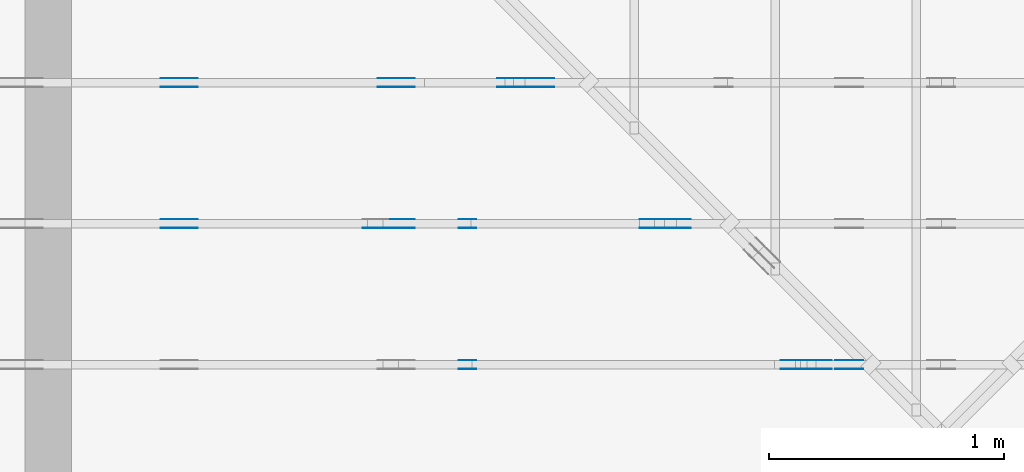
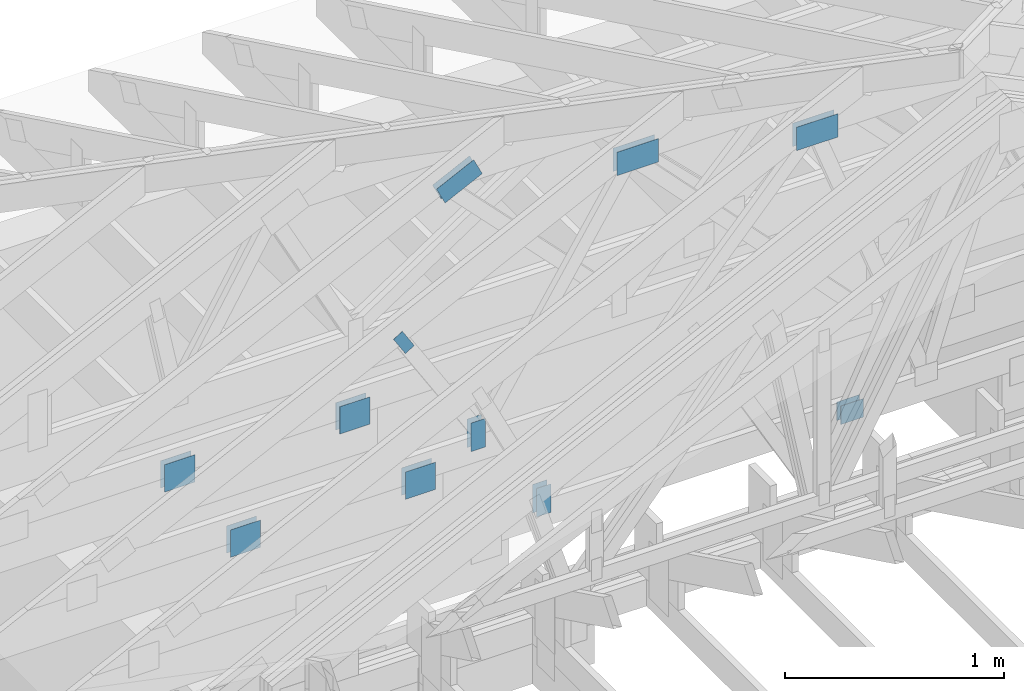
# One storey, part 105 of 159: 21 plates, 3 elements without a shape of their own.
"""IFC2X3 building model written with IfcOpenShell, lengths in millimetres."""

from ifc_helpers import new_model, si_unit, frame, origin, origin_with_axes, origin_2d, place, context, project, spatial, faceted_brep, element, aggregate, save


model = new_model("IFC2X3")

# Units and contexts
model_context = context("Model", 3, precision=1e-05, world=origin())
plan_context = context("Plan", 2, precision=1e-05, world=origin_2d())
ifc_project = project(units=[si_unit("LENGTHUNIT", "METRE", prefix="MILLI"), si_unit("AREAUNIT", "SQUARE_METRE"), si_unit("VOLUMEUNIT", "CUBIC_METRE"), si_unit("SOLIDANGLEUNIT", "STERADIAN"), si_unit("PLANEANGLEUNIT", "RADIAN"), si_unit("MASSUNIT", "GRAM"), si_unit("TIMEUNIT", "SECOND"), si_unit("THERMODYNAMICTEMPERATUREUNIT", "DEGREE_CELSIUS"), si_unit("LUMINOUSINTENSITYUNIT", "LUMEN")], contexts=[model_context, plan_context])

# Site, building, storey
site_placement = place(None, origin_with_axes())
site = spatial("IfcSite", under=ifc_project, at=site_placement, CompositionType="ELEMENT")
building_placement = place(site_placement, origin_with_axes())
building = spatial("IfcBuilding", under=site, at=building_placement, Name="Plan 1", CompositionType="ELEMENT")
storey_placement = place(building_placement, origin_with_axes())
storey = spatial("IfcBuildingStorey", under=building, at=storey_placement, Name="Etasje 1", CompositionType="ELEMENT", Elevation=0.0)

# Assembly, plates
assembly_1_placement = place(storey_placement, frame((19200.01266310149, 9617.999978540158, 1.1021457184401395e-15), z_axis=(1.2246063538223773e-16, 1.0, 6.123031769111886e-17), x_axis=(-1.0, 1.2246063538223773e-16, 0.0)))
assembly_1 = element("IfcElementAssembly", 1, at=assembly_1_placement, inside=storey, Name="V12 (104)", AssemblyPlace="FACTORY", PredefinedType="TRUSS")
plate_1_placement = place(assembly_1_placement, frame((5283.707678150258, 1983.6011962890625, 0.0), z_axis=(0.0, 0.0, 1.0), x_axis=(-1.0, 1.2246063538223773e-16, 0.0)))
plate_1 = element("IfcPlate", 2, at=plate_1_placement, Name="GNT100S 130x218", context=model_context, shape_type="Brep", body=[
    faceted_brep([(218.0001586190083, 130.0, 1.0), (0.0001586190082889516, 130.0, 1.0), (0.0001586190082889516, 0.0, 1.0), (218.0001586190083, 0.0, 1.0), (0.0001586190082889516, 130.0, 1.9424584538765444e-20), (218.0001586190083, 130.0, 2.6696437937912362e-14), (218.0001586190083, 0.0, 2.6696437937912362e-14), (0.0001586190082889516, 0.0, 1.9424584538765444e-20), (218.0, 3.960855538568509e-05, 2.4519454227078848e-30), (218.0, 3.960855538574632e-05, 1.0), (1.1247455413666031e-32, 3.960855542579095e-05, 1.0), (0.0, 3.960855542572972e-05, 0.0), (218.0, 130.00003960855543, 0.0), (218.0, 130.00003960855543, 1.0), (218.0, 3.960855542572972e-05, 1.0), (218.0, 3.960855542572972e-05, 0.0), (0.0, 130.00003960855543, 0.0), (-3.7491518045553436e-33, 130.00003960855543, 1.0), (218.0, 130.00003960855543, 1.0), (218.0, 130.00003960855543, -1.5777218104420236e-30), (4.850488864007441e-21, 3.960855542572972e-05, -2.9699697410040984e-37), (6.123516817998287e-17, 3.960855542572972e-05, 1.0), (1.5981117767870887e-14, 130.00003960855543, 1.0), (1.591988745017977e-14, 130.00003960855543, -9.747797661813634e-31)], [[[0, 1, 2, 3]], [[4, 5, 6, 7]], [[8, 9, 10, 11]], [[12, 13, 14, 15]], [[16, 17, 18, 19]], [[20, 21, 22, 23]]]),
])
plate_2_placement = place(assembly_1_placement, frame((5283.707678150258, 1983.6011962890625, -37.0), z_axis=(0.0, 0.0, 1.0), x_axis=(-1.0, 1.2246063538223773e-16, 0.0)))
plate_2 = element("IfcPlate", 3, at=plate_2_placement, Name="GNT100S 130x218", context=model_context, shape_type="Brep", body=[
    faceted_brep([(218.0001586190083, 130.0, 1.0), (0.0001586190082889516, 130.0, 1.0), (0.0001586190082889516, 0.0, 1.0), (218.0001586190083, 0.0, 1.0), (0.0001586190082889516, 130.0, 1.9424584538765444e-20), (218.0001586190083, 130.0, 2.6696437937912362e-14), (218.0001586190083, 0.0, 2.6696437937912362e-14), (0.0001586190082889516, 0.0, 1.9424584538765444e-20), (218.0, 3.960855538568509e-05, 2.4519454227078848e-30), (218.0, 3.960855538574632e-05, 1.0), (1.1247455413666031e-32, 3.960855542579095e-05, 1.0), (0.0, 3.960855542572972e-05, 0.0), (218.0, 130.00003960855543, 0.0), (218.0, 130.00003960855543, 1.0), (218.0, 3.960855542572972e-05, 1.0), (218.0, 3.960855542572972e-05, 0.0), (0.0, 130.00003960855543, 0.0), (-3.7491518045553436e-33, 130.00003960855543, 1.0), (218.0, 130.00003960855543, 1.0), (218.0, 130.00003960855543, -1.5777218104420236e-30), (4.850488864007441e-21, 3.960855542572972e-05, -2.9699697410040984e-37), (6.123516817998287e-17, 3.960855542572972e-05, 1.0), (1.5981117767870887e-14, 130.00003960855543, 1.0), (1.591988745017977e-14, 130.00003960855543, -9.747797661813634e-31)], [[[0, 1, 2, 3]], [[4, 5, 6, 7]], [[8, 9, 10, 11]], [[12, 13, 14, 15]], [[16, 17, 18, 19]], [[20, 21, 22, 23]]]),
])
plate_3_placement = place(assembly_1_placement, frame((6654.000000003588, 291.5, 0.0), z_axis=(0.0, 0.0, 1.0), x_axis=(6.123031769111886e-17, 1.0, 0.0)))
plate_3 = element("IfcPlate", 4, at=plate_3_placement, Name="GNT100S 76x159", context=model_context, shape_type="Brep", body=[
    faceted_brep([(159.0, 76.00000000358796, 1.0), (0.0, 76.00000000358796, 1.0), (0.0, 3.587956598494202e-09, 1.0), (159.0, 3.587956598494202e-09, 1.0), (0.0, 76.00000000358796, 0.0), (159.0, 76.00000000358796, 1.9471241025775798e-14), (159.0, 3.587956598494202e-09, 1.9471241025775798e-14), (0.0, 3.587956598494202e-09, 0.0), (159.00000000000057, -2.9206861538663805e-14, 1.7883454107729052e-30), (159.00000000000057, -2.9145631220972686e-14, 1.0), (5.684341886080801e-13, 6.123031769101445e-17, 1.0), (5.684341886080801e-13, -1.0441621786489838e-28, 6.393438191972809e-45), (159.00000000000057, 76.0, 0.0), (159.00000000000057, 76.0, 1.0), (159.00000000000057, 0.0, 1.0), (159.00000000000057, 0.0, 0.0), (5.684341886080801e-13, 76.0, 0.0), (5.684341886080801e-13, 76.0, 1.0), (159.00000000000057, 75.99999999999999, 1.0), (159.00000000000057, 75.99999999999999, -7.888609052210118e-31), (5.684341886080801e-13, 0.0, 0.0), (5.684954189257713e-13, -7.498303609110687e-33, 1.0), (5.778024272148213e-13, 76.0, 1.0), (5.777411968971302e-13, 76.0, -5.698710742924122e-31)], [[[0, 1, 2, 3]], [[4, 5, 6, 7]], [[8, 9, 10, 11]], [[12, 13, 14, 15]], [[16, 17, 18, 19]], [[20, 21, 22, 23]]]),
])
plate_4_placement = place(assembly_1_placement, frame((6654.000000003588, 291.5, -37.0), z_axis=(0.0, 0.0, 1.0), x_axis=(6.123031769111886e-17, 1.0, 0.0)))
plate_4 = element("IfcPlate", 5, at=plate_4_placement, Name="GNT100S 76x159", context=model_context, shape_type="Brep", body=[
    faceted_brep([(159.0, 76.00000000358796, 1.0), (0.0, 76.00000000358796, 1.0), (0.0, 3.587956598494202e-09, 1.0), (159.0, 3.587956598494202e-09, 1.0), (0.0, 76.00000000358796, 0.0), (159.0, 76.00000000358796, 1.9471241025775798e-14), (159.0, 3.587956598494202e-09, 1.9471241025775798e-14), (0.0, 3.587956598494202e-09, 0.0), (159.00000000000057, -2.9206861538663805e-14, 1.7883454107729052e-30), (159.00000000000057, -2.9145631220972686e-14, 1.0), (5.684341886080801e-13, 6.123031769101445e-17, 1.0), (5.684341886080801e-13, -1.0441621786489838e-28, 6.393438191972809e-45), (159.00000000000057, 76.0, 0.0), (159.00000000000057, 76.0, 1.0), (159.00000000000057, 0.0, 1.0), (159.00000000000057, 0.0, 0.0), (5.684341886080801e-13, 76.0, 0.0), (5.684341886080801e-13, 76.0, 1.0), (159.00000000000057, 75.99999999999999, 1.0), (159.00000000000057, 75.99999999999999, -7.888609052210118e-31), (5.684341886080801e-13, 0.0, 0.0), (5.684954189257713e-13, -7.498303609110687e-33, 1.0), (5.778024272148213e-13, 76.0, 1.0), (5.777411968971302e-13, 76.0, -5.698710742924122e-31)], [[[0, 1, 2, 3]], [[4, 5, 6, 7]], [[8, 9, 10, 11]], [[12, 13, 14, 15]], [[16, 17, 18, 19]], [[20, 21, 22, 23]]]),
])
plate_5_placement = place(assembly_1_placement, frame((5050.681295681745, 348.5000000000011, 0.0), z_axis=(0.0, 0.0, 1.0), x_axis=(-1.0, 1.2246063538223773e-16, 0.0)))
plate_5 = element("IfcPlate", 6, at=plate_5_placement, Name="GNT100S 103x119", context=model_context, shape_type="Brep", body=[
    faceted_brep([(119.00014333799481, 103.00000000000108, 1.0), (0.00014333799481391907, 103.00000000000108, 1.0), (0.00014333799481391907, 1.0800249583553523e-12, 1.0), (119.00014333799481, 1.0800249583553523e-12, 1.0), (0.00014333799481391907, 103.00000000000108, 1.7553261919328425e-20), (119.00014333799481, 103.00000000000108, 1.457283316374821e-14), (119.00014333799481, 1.0800249583553523e-12, 1.457283316374821e-14), (0.00014333799481391907, 1.0800249583553523e-12, 1.7553261919328425e-20), (119.0, -2.1859223415729434e-14, 1.3384471942262577e-30), (119.0, -2.1797993098038315e-14, 1.0), (1.1247455413666031e-32, 6.123031769111886e-17, 1.0), (0.0, 0.0, 0.0), (119.0, 103.00000000000003, 0.0), (119.0, 103.00000000000003, 1.0), (119.0, 0.0, 1.0), (119.0, 0.0, 0.0), (0.0, 103.0, 0.0), (0.0, 103.0, 1.0), (119.0, 103.00000000000001, 1.0), (119.0, 103.00000000000001, -7.888609052210118e-31), (0.0, 0.0, 0.0), (6.123031769111886e-17, -7.498303609110687e-33, 1.0), (1.2674675762061605e-14, 103.0, 1.0), (1.2613445444370486e-14, 103.0, -7.723252717384008e-31)], [[[0, 1, 2, 3]], [[4, 5, 6, 7]], [[8, 9, 10, 11]], [[12, 13, 14, 15]], [[16, 17, 18, 19]], [[20, 21, 22, 23]]]),
])
plate_6_placement = place(assembly_1_placement, frame((5050.681295681745, 348.5000000000011, -37.0), z_axis=(0.0, 0.0, 1.0), x_axis=(-1.0, 1.2246063538223773e-16, 0.0)))
plate_6 = element("IfcPlate", 7, at=plate_6_placement, Name="GNT100S 103x119", context=model_context, shape_type="Brep", body=[
    faceted_brep([(119.00014333799481, 103.00000000000108, 1.0), (0.00014333799481391907, 103.00000000000108, 1.0), (0.00014333799481391907, 1.0800249583553523e-12, 1.0), (119.00014333799481, 1.0800249583553523e-12, 1.0), (0.00014333799481391907, 103.00000000000108, 1.7553261919328425e-20), (119.00014333799481, 103.00000000000108, 1.457283316374821e-14), (119.00014333799481, 1.0800249583553523e-12, 1.457283316374821e-14), (0.00014333799481391907, 1.0800249583553523e-12, 1.7553261919328425e-20), (119.0, -2.1859223415729434e-14, 1.3384471942262577e-30), (119.0, -2.1797993098038315e-14, 1.0), (1.1247455413666031e-32, 6.123031769111886e-17, 1.0), (0.0, 0.0, 0.0), (119.0, 103.00000000000003, 0.0), (119.0, 103.00000000000003, 1.0), (119.0, 0.0, 1.0), (119.0, 0.0, 0.0), (0.0, 103.0, 0.0), (0.0, 103.0, 1.0), (119.0, 103.00000000000001, 1.0), (119.0, 103.00000000000001, -7.888609052210118e-31), (0.0, 0.0, 0.0), (6.123031769111886e-17, -7.498303609110687e-33, 1.0), (1.2674675762061605e-14, 103.0, 1.0), (1.2613445444370486e-14, 103.0, -7.723252717384008e-31)], [[[0, 1, 2, 3]], [[4, 5, 6, 7]], [[8, 9, 10, 11]], [[12, 13, 14, 15]], [[16, 17, 18, 19]], [[20, 21, 22, 23]]]),
])
aggregate(assembly_1, [plate_1, plate_2, plate_3, plate_4, plate_5, plate_6])

assembly_2_placement = place(storey_placement, frame((19200.01266310149, 10817.999978540158, 1.1021457184401395e-15), z_axis=(1.2246063538223773e-16, 1.0, 6.123031769111886e-17), x_axis=(-1.0, 1.2246063538223773e-16, 0.0)))
assembly_2 = element("IfcElementAssembly", 8, at=assembly_2_placement, inside=storey, Name="V10 (59)", AssemblyPlace="FACTORY", PredefinedType="TRUSS")
plate_7_placement = place(assembly_2_placement, frame((6840.0, 146.99999999959994, 0.0), z_axis=(0.0, 0.0, 1.0), x_axis=(1.0, 0.0, 0.0)))
plate_7 = element("IfcPlate", 9, at=plate_7_placement, Name="GNT100S 152x159", context=model_context, shape_type="Brep", body=[
    faceted_brep([(159.0, 152.00000000040006, 1.0), (0.0, 152.00000000040006, 1.0), (0.0, 4.000639819423668e-10, 1.0), (159.0, 4.000639819423668e-10, 1.0), (0.0, 152.00000000040006, 0.0), (159.0, 152.00000000040006, 1.9471241025775798e-14), (159.0, 4.000639819423668e-10, 1.9471241025775798e-14), (0.0, 4.000639819423668e-10, 0.0), (159.0, -2.92068615386637e-14, 1.788345410772899e-30), (159.0, -2.914563122097258e-14, 1.0), (1.1247455413666031e-32, 6.123031769111886e-17, 1.0), (0.0, 0.0, 0.0), (159.0, 152.0, 0.0), (159.0, 152.0, 1.0), (159.0, 0.0, 1.0), (159.0, 0.0, 0.0), (0.0, 152.0, 0.0), (-3.7491518045553436e-33, 152.0, 1.0), (159.0, 152.0, 1.0), (159.0, 152.0, 0.0), (0.0, 0.0, 0.0), (6.123031769111886e-17, -7.498303609110687e-33, 1.0), (1.8675246895791253e-14, 152.0, 1.0), (1.8614016578100134e-14, 152.0, -1.1397421485848245e-30)], [[[0, 1, 2, 3]], [[4, 5, 6, 7]], [[8, 9, 10, 11]], [[12, 13, 14, 15]], [[16, 17, 18, 19]], [[20, 21, 22, 23]]]),
])
plate_8_placement = place(assembly_2_placement, frame((6840.0, 146.99999999959994, -37.0), z_axis=(0.0, 0.0, 1.0), x_axis=(1.0, 0.0, 0.0)))
plate_8 = element("IfcPlate", 10, at=plate_8_placement, Name="GNT100S 152x159", context=model_context, shape_type="Brep", body=[
    faceted_brep([(159.0, 152.00000000040006, 1.0), (0.0, 152.00000000040006, 1.0), (0.0, 4.000639819423668e-10, 1.0), (159.0, 4.000639819423668e-10, 1.0), (0.0, 152.00000000040006, 0.0), (159.0, 152.00000000040006, 1.9471241025775798e-14), (159.0, 4.000639819423668e-10, 1.9471241025775798e-14), (0.0, 4.000639819423668e-10, 0.0), (159.0, -2.92068615386637e-14, 1.788345410772899e-30), (159.0, -2.914563122097258e-14, 1.0), (1.1247455413666031e-32, 6.123031769111886e-17, 1.0), (0.0, 0.0, 0.0), (159.0, 152.0, 0.0), (159.0, 152.0, 1.0), (159.0, 0.0, 1.0), (159.0, 0.0, 0.0), (0.0, 152.0, 0.0), (-3.7491518045553436e-33, 152.0, 1.0), (159.0, 152.0, 1.0), (159.0, 152.0, 0.0), (0.0, 0.0, 0.0), (6.123031769111886e-17, -7.498303609110687e-33, 1.0), (1.8675246895791253e-14, 152.0, 1.0), (1.8614016578100134e-14, 152.0, -1.1397421485848245e-30)], [[[0, 1, 2, 3]], [[4, 5, 6, 7]], [[8, 9, 10, 11]], [[12, 13, 14, 15]], [[16, 17, 18, 19]], [[20, 21, 22, 23]]]),
])
plate_9_placement = place(assembly_2_placement, frame((7763.148717704301, 146.99999999938686, 0.0), z_axis=(0.0, 0.0, 1.0), x_axis=(1.0, 0.0, 0.0)))
plate_9 = element("IfcPlate", 11, at=plate_9_placement, Name="GNT100S 152x159", context=model_context, shape_type="Brep", body=[
    faceted_brep([(159.0002080769491, 152.00000000061314, 1.0), (0.00020807694909308339, 152.00000000061314, 1.0), (0.00020807694909308339, 6.131415375421057e-10, 1.0), (159.0002080769491, 6.131415375421057e-10, 1.0), (0.00020807694909308339, 152.00000000061314, 2.5481235394336525e-20), (159.0002080769491, 152.00000000061314, 1.9471266507011194e-14), (159.0002080769491, 6.131415375421057e-10, 1.9471266507011194e-14), (0.00020807694909308339, 6.131415375421057e-10, 2.5481235394336525e-20), (159.0, -2.92068615386637e-14, 1.788345410772899e-30), (159.0, -2.914563122097258e-14, 1.0), (1.1247455413666031e-32, 6.123031769111886e-17, 1.0), (0.0, 0.0, 0.0), (159.0, 152.00000000000003, 0.0), (159.0, 152.00000000000003, 1.0), (159.0, 0.0, 1.0), (159.0, 0.0, 0.0), (0.0, 152.00000000000003, 0.0), (-3.7491518045553436e-33, 152.00000000000003, 1.0), (159.0, 152.00000000000003, 1.0), (159.0, 152.00000000000003, 0.0), (0.0, 0.0, 0.0), (6.123031769111886e-17, -7.498303609110687e-33, 1.0), (1.8675246895791256e-14, 152.00000000000003, 1.0), (1.8614016578100137e-14, 152.00000000000003, -1.1397421485848246e-30)], [[[0, 1, 2, 3]], [[4, 5, 6, 7]], [[8, 9, 10, 11]], [[12, 13, 14, 15]], [[16, 17, 18, 19]], [[20, 21, 22, 23]]]),
])
plate_10_placement = place(assembly_2_placement, frame((7763.148717704301, 146.99999999938686, -37.0), z_axis=(0.0, 0.0, 1.0), x_axis=(1.0, 0.0, 0.0)))
plate_10 = element("IfcPlate", 12, at=plate_10_placement, Name="GNT100S 152x159", context=model_context, shape_type="Brep", body=[
    faceted_brep([(159.0002080769491, 152.00000000061314, 1.0), (0.00020807694909308339, 152.00000000061314, 1.0), (0.00020807694909308339, 6.131415375421057e-10, 1.0), (159.0002080769491, 6.131415375421057e-10, 1.0), (0.00020807694909308339, 152.00000000061314, 2.5481235394336525e-20), (159.0002080769491, 152.00000000061314, 1.9471266507011194e-14), (159.0002080769491, 6.131415375421057e-10, 1.9471266507011194e-14), (0.00020807694909308339, 6.131415375421057e-10, 2.5481235394336525e-20), (159.0, -2.92068615386637e-14, 1.788345410772899e-30), (159.0, -2.914563122097258e-14, 1.0), (1.1247455413666031e-32, 6.123031769111886e-17, 1.0), (0.0, 0.0, 0.0), (159.0, 152.00000000000003, 0.0), (159.0, 152.00000000000003, 1.0), (159.0, 0.0, 1.0), (159.0, 0.0, 0.0), (0.0, 152.00000000000003, 0.0), (-3.7491518045553436e-33, 152.00000000000003, 1.0), (159.0, 152.00000000000003, 1.0), (159.0, 152.00000000000003, 0.0), (0.0, 0.0, 0.0), (6.123031769111886e-17, -7.498303609110687e-33, 1.0), (1.8675246895791256e-14, 152.00000000000003, 1.0), (1.8614016578100137e-14, 152.00000000000003, -1.1397421485848246e-30)], [[[0, 1, 2, 3]], [[4, 5, 6, 7]], [[8, 9, 10, 11]], [[12, 13, 14, 15]], [[16, 17, 18, 19]], [[20, 21, 22, 23]]]),
])
plate_11_placement = place(assembly_2_placement, frame((6489.082371006192, 1333.1678824113746, 0.0), z_axis=(0.0, 0.0, 1.0), x_axis=(-0.898794046299167, 0.4383711467890773, 0.0)))
plate_11 = element("IfcPlate", 13, at=plate_11_placement, Name="GNT100S 103x218", context=model_context, shape_type="Brep", body=[
    faceted_brep([(218.0003714038321, 102.99992496236837, 1.0), (0.0, 102.99992496236837, 1.0), (0.00034321920520596905, 7.133866938602296e-05, 1.0), (218.0002757587563, 7.133866938602296e-05, 1.0), (0.0, 102.99992496236837, 0.0), (218.0003714038321, 102.99992496236837, 2.6696463995677088e-14), (218.0002757587563, 3.4933759707200807e-06, 2.6696452282920332e-14), (0.00034321920520596905, 3.4933759707200807e-06, 4.2030841944909604e-20), (218.00014171649218, -4.0044653802029254e-14, 2.451946874129122e-30), (218.00014171649218, -3.9983423484338135e-14, 1.0), (0.00014171649308991618, 6.120428565343696e-17, 1.0), (0.00014171649308991618, -2.6032037681900457e-20, 1.5939499374099424e-36), (218.00014171649218, 102.99999999999955, -5.522026336547083e-29), (218.00014171649218, 102.99999999999955, 1.0), (218.00014171649218, 0.0, 1.0), (218.00014171649218, 0.0, 0.0), (0.00014171649218042148, 102.99999999999955, 0.0), (0.00014171649218042148, 102.99999999999955, 1.0), (218.0001417164931, 102.99999999999953, 1.0), (218.0001417164931, 102.99999999999953, -7.888609052210118e-31), (0.00014171649308991618, 0.0, 0.0), (0.00014171649308997741, 5.363714895118452e-31, 1.0), (0.0001417164921877671, 102.99999999999955, 1.0), (0.00014171649218770586, 102.99999999999955, -4.460243102613171e-31)], [[[0, 1, 2, 3]], [[4, 5, 6, 7]], [[8, 9, 10, 11]], [[12, 13, 14, 15]], [[16, 17, 18, 19]], [[20, 21, 22, 23]]]),
])
plate_12_placement = place(assembly_2_placement, frame((6489.082371006192, 1333.1678824113746, -37.0), z_axis=(0.0, 0.0, 1.0), x_axis=(-0.898794046299167, 0.4383711467890773, 0.0)))
plate_12 = element("IfcPlate", 14, at=plate_12_placement, Name="GNT100S 103x218", context=model_context, shape_type="Brep", body=[
    faceted_brep([(218.0003714038321, 102.99992496236837, 1.0), (0.0, 102.99992496236837, 1.0), (0.00034321920520596905, 7.133866938602296e-05, 1.0), (218.0002757587563, 7.133866938602296e-05, 1.0), (0.0, 102.99992496236837, 0.0), (218.0003714038321, 102.99992496236837, 2.6696463995677088e-14), (218.0002757587563, 3.4933759707200807e-06, 2.6696452282920332e-14), (0.00034321920520596905, 3.4933759707200807e-06, 4.2030841944909604e-20), (218.00014171649218, -4.0044653802029254e-14, 2.451946874129122e-30), (218.00014171649218, -3.9983423484338135e-14, 1.0), (0.00014171649308991618, 6.120428565343696e-17, 1.0), (0.00014171649308991618, -2.6032037681900457e-20, 1.5939499374099424e-36), (218.00014171649218, 102.99999999999955, -5.522026336547083e-29), (218.00014171649218, 102.99999999999955, 1.0), (218.00014171649218, 0.0, 1.0), (218.00014171649218, 0.0, 0.0), (0.00014171649218042148, 102.99999999999955, 0.0), (0.00014171649218042148, 102.99999999999955, 1.0), (218.0001417164931, 102.99999999999953, 1.0), (218.0001417164931, 102.99999999999953, -7.888609052210118e-31), (0.00014171649308991618, 0.0, 0.0), (0.00014171649308997741, 5.363714895118452e-31, 1.0), (0.0001417164921877671, 102.99999999999955, 1.0), (0.00014171649218770586, 102.99999999999955, -4.460243102613171e-31)], [[[0, 1, 2, 3]], [[4, 5, 6, 7]], [[8, 9, 10, 11]], [[12, 13, 14, 15]], [[16, 17, 18, 19]], [[20, 21, 22, 23]]]),
])
aggregate(assembly_2, [plate_7, plate_8, plate_9, plate_10, plate_11, plate_12])

assembly_3_placement = place(storey_placement, frame((19200.01266310149, 10217.999978540158, 1.1021457184401395e-15), z_axis=(1.2246063538223773e-16, 1.0, 6.123031769111886e-17), x_axis=(-1.0, 1.2246063538223773e-16, 0.0)))
assembly_3 = element("IfcElementAssembly", 15, at=assembly_3_placement, inside=storey, Name="V11 (60)", AssemblyPlace="FACTORY", PredefinedType="TRUSS")
plate_13_placement = place(assembly_3_placement, frame((5883.707757287255, 1690.9615649437226, 0.0), z_axis=(0.0, 0.0, 1.0), x_axis=(-1.0, 1.2246063538223773e-16, 0.0)))
plate_13 = element("IfcPlate", 16, at=plate_13_placement, Name="GNT100S 130x218", context=model_context, shape_type="Brep", body=[
    faceted_brep([(218.00023775600494, 130.00001709216008, 1.0), (0.0002377560049353633, 130.00001709216008, 1.0), (0.0002377560049353633, 1.7092160078391316e-05, 1.0), (218.00023775600494, 1.7092160078391316e-05, 1.0), (0.0002377560049353633, 130.00001709216008, 2.911575143032704e-20), (218.00023775600494, 130.00001709216008, 2.6696447629079254e-14), (218.00023775600494, 1.7092160078391316e-05, 2.6696447629079254e-14), (0.0002377560049353633, 1.7092160078391316e-05, 2.911575143032704e-20), (218.0, -4.0044627769991736e-14, 2.4519452801791947e-30), (218.0, -3.998339745230062e-14, 1.0), (1.1247455413666031e-32, 6.123031769111886e-17, 1.0), (0.0, 0.0, 0.0), (218.0, 130.0, 0.0), (218.0, 130.0, 1.0), (218.0, 0.0, 1.0), (218.0, 0.0, 0.0), (0.0, 130.0, 0.0), (-3.7491518045553436e-33, 130.0, 1.0), (218.0, 130.0, 1.0), (218.0, 130.0, -1.5777218104420236e-30), (0.0, 0.0, 0.0), (6.123031769111886e-17, -7.498303609110687e-33, 1.0), (1.5981112917382023e-14, 130.0, 1.0), (1.5919882599690904e-14, 130.0, -9.747794691843893e-31)], [[[0, 1, 2, 3]], [[4, 5, 6, 7]], [[8, 9, 10, 11]], [[12, 13, 14, 15]], [[16, 17, 18, 19]], [[20, 21, 22, 23]]]),
])
plate_14_placement = place(assembly_3_placement, frame((5883.707757287255, 1690.9615649437226, -37.0), z_axis=(0.0, 0.0, 1.0), x_axis=(-1.0, 1.2246063538223773e-16, 0.0)))
plate_14 = element("IfcPlate", 17, at=plate_14_placement, Name="GNT100S 130x218", context=model_context, shape_type="Brep", body=[
    faceted_brep([(218.00023775600494, 130.00001709216008, 1.0), (0.0002377560049353633, 130.00001709216008, 1.0), (0.0002377560049353633, 1.7092160078391316e-05, 1.0), (218.00023775600494, 1.7092160078391316e-05, 1.0), (0.0002377560049353633, 130.00001709216008, 2.911575143032704e-20), (218.00023775600494, 130.00001709216008, 2.6696447629079254e-14), (218.00023775600494, 1.7092160078391316e-05, 2.6696447629079254e-14), (0.0002377560049353633, 1.7092160078391316e-05, 2.911575143032704e-20), (218.0, -4.0044627769991736e-14, 2.4519452801791947e-30), (218.0, -3.998339745230062e-14, 1.0), (1.1247455413666031e-32, 6.123031769111886e-17, 1.0), (0.0, 0.0, 0.0), (218.0, 130.0, 0.0), (218.0, 130.0, 1.0), (218.0, 0.0, 1.0), (218.0, 0.0, 0.0), (0.0, 130.0, 0.0), (-3.7491518045553436e-33, 130.0, 1.0), (218.0, 130.0, 1.0), (218.0, 130.0, -1.5777218104420236e-30), (0.0, 0.0, 0.0), (6.123031769111886e-17, -7.498303609110687e-33, 1.0), (1.5981112917382023e-14, 130.0, 1.0), (1.5919882599690904e-14, 130.0, -9.747794691843893e-31)], [[[0, 1, 2, 3]], [[4, 5, 6, 7]], [[8, 9, 10, 11]], [[12, 13, 14, 15]], [[16, 17, 18, 19]], [[20, 21, 22, 23]]]),
])
plate_15_placement = place(assembly_3_placement, frame((7015.7894088126795, 1089.6319242376067, -37.0), z_axis=(0.0, 0.0, 1.0), x_axis=(-0.5281471129139604, -0.8491528879540176, 0.0)))
plate_15 = element("IfcPlate", 18, at=plate_15_placement, Name="GNT100S 55x119", context=model_context, shape_type="Brep", body=[
    faceted_brep([(119.00026048620748, 54.999928539949906, 1.0), (0.00015372306370409206, 54.999928539949906, 1.0), (0.0, 0.0001671884674578905, 1.0), (119.00010676314378, 0.0001671884674578905, 1.0), (0.00015372306370409206, 54.999928539949906, 1.882502405410732e-20), (119.00026048620748, 54.999928539949906, 1.4572847509792764e-14), (119.00010676314378, 0.00011236725367780309, 1.457282868476871e-14), (0.0, 0.00011236725367780309, 0.0), (119.00017563870642, -6.360370301773296e-14, 3.8944749421073696e-30), (119.00017563870642, -6.354247270004184e-14, 1.0), (0.00017563870642334223, 9.095558382145217e-13, 1.0), (0.00017563870642334223, 9.094946078968306e-13, 5.748063287071056e-36), (119.00017563870642, 55.0, 0.0), (119.00017563870642, 55.0, 1.0), (119.00017563870642, 0.0, 1.0), (119.00017563870642, 0.0, 0.0), (0.00017563870642334223, 55.0, 0.0), (0.00017563870642334223, 55.0, 1.0), (119.00017563870642, 54.99999999999999, 1.0), (119.00017563870642, 54.99999999999999, -3.944304526105059e-31), (0.00017563870642334223, 9.094947017729281e-13, 0.0), (0.00017563870642340346, 9.094947017729281e-13, 1.0), (0.0001756387064301388, 55.0, 1.0), (0.00017563870643007756, 55.0, -4.1240630030237645e-31)], [[[0, 1, 2, 3]], [[4, 5, 6, 7]], [[8, 9, 10, 11]], [[12, 13, 14, 15]], [[16, 17, 18, 19]], [[20, 21, 22, 23]]]),
])
plate_16_placement = place(assembly_3_placement, frame((6654.00000000185, 291.5, 0.0), z_axis=(0.0, 0.0, 1.0), x_axis=(6.123031769111886e-17, 1.0, 0.0)))
plate_16 = element("IfcPlate", 19, at=plate_16_placement, Name="GNT100S 76x159", context=model_context, shape_type="Brep", body=[
    faceted_brep([(159.0, 76.00000000184991, 1.0), (0.0, 76.00000000184991, 1.0), (0.0, 1.849912223406136e-09, 1.0), (159.0, 1.849912223406136e-09, 1.0), (0.0, 76.00000000184991, 0.0), (159.0, 76.00000000184991, 1.9471241025775798e-14), (159.0, 1.849912223406136e-09, 1.9471241025775798e-14), (0.0, 1.849912223406136e-09, 0.0), (159.00000000000068, -2.9206861538663824e-14, 1.7883454107729066e-30), (159.00000000000068, -2.9145631220972705e-14, 1.0), (6.821210263296962e-13, 6.123031769099356e-17, 1.0), (6.821210263296962e-13, -1.2529946143787805e-28, 7.67212583036737e-45), (159.00000000000068, 76.0, 0.0), (159.00000000000068, 76.0, 1.0), (159.00000000000068, 0.0, 1.0), (159.00000000000068, 0.0, 0.0), (6.821210263296962e-13, 76.0, 0.0), (6.821210263296962e-13, 76.0, 1.0), (159.00000000000068, 75.99999999999999, 1.0), (159.00000000000068, 75.99999999999999, -7.888609052210118e-31), (6.821210263296962e-13, 0.0, 0.0), (6.821822566473873e-13, -7.498303609110687e-33, 1.0), (6.914892649364374e-13, 76.0, 1.0), (6.914280346187462e-13, 76.0, -5.698710742924122e-31)], [[[0, 1, 2, 3]], [[4, 5, 6, 7]], [[8, 9, 10, 11]], [[12, 13, 14, 15]], [[16, 17, 18, 19]], [[20, 21, 22, 23]]]),
])
plate_17_placement = place(assembly_3_placement, frame((6654.00000000185, 291.5, -37.0), z_axis=(0.0, 0.0, 1.0), x_axis=(6.123031769111886e-17, 1.0, 0.0)))
plate_17 = element("IfcPlate", 20, at=plate_17_placement, Name="GNT100S 76x159", context=model_context, shape_type="Brep", body=[
    faceted_brep([(159.0, 76.00000000184991, 1.0), (0.0, 76.00000000184991, 1.0), (0.0, 1.849912223406136e-09, 1.0), (159.0, 1.849912223406136e-09, 1.0), (0.0, 76.00000000184991, 0.0), (159.0, 76.00000000184991, 1.9471241025775798e-14), (159.0, 1.849912223406136e-09, 1.9471241025775798e-14), (0.0, 1.849912223406136e-09, 0.0), (159.00000000000068, -2.9206861538663824e-14, 1.7883454107729066e-30), (159.00000000000068, -2.9145631220972705e-14, 1.0), (6.821210263296962e-13, 6.123031769099356e-17, 1.0), (6.821210263296962e-13, -1.2529946143787805e-28, 7.67212583036737e-45), (159.00000000000068, 76.0, 0.0), (159.00000000000068, 76.0, 1.0), (159.00000000000068, 0.0, 1.0), (159.00000000000068, 0.0, 0.0), (6.821210263296962e-13, 76.0, 0.0), (6.821210263296962e-13, 76.0, 1.0), (159.00000000000068, 75.99999999999999, 1.0), (159.00000000000068, 75.99999999999999, -7.888609052210118e-31), (6.821210263296962e-13, 0.0, 0.0), (6.821822566473873e-13, -7.498303609110687e-33, 1.0), (6.914892649364374e-13, 76.0, 1.0), (6.914280346187462e-13, 76.0, -5.698710742924122e-31)], [[[0, 1, 2, 3]], [[4, 5, 6, 7]], [[8, 9, 10, 11]], [[12, 13, 14, 15]], [[16, 17, 18, 19]], [[20, 21, 22, 23]]]),
])
plate_18_placement = place(assembly_3_placement, frame((6840.0, 147.0, 0.0), z_axis=(0.0, 0.0, 1.0), x_axis=(1.0, 0.0, 0.0)))
plate_18 = element("IfcPlate", 21, at=plate_18_placement, Name="GNT100S 152x159", context=model_context, shape_type="Brep", body=[
    faceted_brep([(159.0, 152.0, 1.0), (0.0, 152.0, 1.0), (0.0, 0.0, 1.0), (159.0, 0.0, 1.0), (0.0, 152.0, 0.0), (159.0, 152.0, 1.9471241025775798e-14), (159.0, 0.0, 1.9471241025775798e-14), (0.0, 0.0, 0.0), (159.0, 6.529141647910325e-13, 1.788345410772899e-30), (159.0, 6.529753951087236e-13, 1.0), (1.1247455413666031e-32, 6.821822566473873e-13, 1.0), (0.0, 6.821210263296962e-13, 0.0), (159.0, 152.00000000000068, 0.0), (159.0, 152.00000000000068, 1.0), (159.0, 6.821210263296962e-13, 1.0), (159.0, 6.821210263296962e-13, 0.0), (0.0, 152.00000000000068, 0.0), (-3.7491518045553436e-33, 152.00000000000068, 1.0), (159.0, 152.00000000000068, 1.0), (159.0, 152.00000000000068, 0.0), (8.35329742919187e-29, 6.821210263296962e-13, -5.114750553578247e-45), (6.12303176912024e-17, 6.821210263296962e-13, 1.0), (1.8675246895791335e-14, 152.00000000000068, 1.0), (1.8614016578100216e-14, 152.00000000000068, -1.1397421485848295e-30)], [[[0, 1, 2, 3]], [[4, 5, 6, 7]], [[8, 9, 10, 11]], [[12, 13, 14, 15]], [[16, 17, 18, 19]], [[20, 21, 22, 23]]]),
])
plate_19_placement = place(assembly_3_placement, frame((6840.0, 147.0, -37.0), z_axis=(0.0, 0.0, 1.0), x_axis=(1.0, 0.0, 0.0)))
plate_19 = element("IfcPlate", 22, at=plate_19_placement, Name="GNT100S 152x159", context=model_context, shape_type="Brep", body=[
    faceted_brep([(159.0, 152.0, 1.0), (0.0, 152.0, 1.0), (0.0, 0.0, 1.0), (159.0, 0.0, 1.0), (0.0, 152.0, 0.0), (159.0, 152.0, 1.9471241025775798e-14), (159.0, 0.0, 1.9471241025775798e-14), (0.0, 0.0, 0.0), (159.0, 6.529141647910325e-13, 1.788345410772899e-30), (159.0, 6.529753951087236e-13, 1.0), (1.1247455413666031e-32, 6.821822566473873e-13, 1.0), (0.0, 6.821210263296962e-13, 0.0), (159.0, 152.00000000000068, 0.0), (159.0, 152.00000000000068, 1.0), (159.0, 6.821210263296962e-13, 1.0), (159.0, 6.821210263296962e-13, 0.0), (0.0, 152.00000000000068, 0.0), (-3.7491518045553436e-33, 152.00000000000068, 1.0), (159.0, 152.00000000000068, 1.0), (159.0, 152.00000000000068, 0.0), (8.35329742919187e-29, 6.821210263296962e-13, -5.114750553578247e-45), (6.12303176912024e-17, 6.821210263296962e-13, 1.0), (1.8675246895791335e-14, 152.00000000000068, 1.0), (1.8614016578100216e-14, 152.00000000000068, -1.1397421485848295e-30)], [[[0, 1, 2, 3]], [[4, 5, 6, 7]], [[8, 9, 10, 11]], [[12, 13, 14, 15]], [[16, 17, 18, 19]], [[20, 21, 22, 23]]]),
])
plate_20_placement = place(assembly_3_placement, frame((7763.148717702976, 147.0, 0.0), z_axis=(0.0, 0.0, 1.0), x_axis=(1.0, 0.0, 0.0)))
plate_20 = element("IfcPlate", 23, at=plate_20_placement, Name="GNT100S 152x159", context=model_context, shape_type="Brep", body=[
    faceted_brep([(159.00020807827423, 152.0, 1.0), (0.00020807827422686387, 152.0, 1.0), (0.00020807827422686387, 0.0, 1.0), (159.00020807827423, 0.0, 1.0), (0.00020807827422686387, 152.0, 2.548139767106125e-20), (159.00020807827423, 152.0, 1.947126650717347e-14), (159.00020807827423, 0.0, 1.947126650717347e-14), (0.00020807827422686387, 0.0, 2.548139767106125e-20), (159.0, 6.529141647910325e-13, 1.788345410772899e-30), (159.0, 6.529753951087236e-13, 1.0), (1.1247455413666031e-32, 6.821822566473873e-13, 1.0), (0.0, 6.821210263296962e-13, 0.0), (159.0, 152.00000000000068, 0.0), (159.0, 152.00000000000068, 1.0), (159.0, 6.821210263296962e-13, 1.0), (159.0, 6.821210263296962e-13, 0.0), (0.0, 152.00000000000068, 0.0), (-3.7491518045553436e-33, 152.00000000000068, 1.0), (159.0, 152.00000000000068, 1.0), (159.0, 152.00000000000068, 0.0), (8.35329742919187e-29, 6.821210263296962e-13, -5.114750553578247e-45), (6.12303176912024e-17, 6.821210263296962e-13, 1.0), (1.8675246895791335e-14, 152.00000000000068, 1.0), (1.8614016578100216e-14, 152.00000000000068, -1.1397421485848295e-30)], [[[0, 1, 2, 3]], [[4, 5, 6, 7]], [[8, 9, 10, 11]], [[12, 13, 14, 15]], [[16, 17, 18, 19]], [[20, 21, 22, 23]]]),
])
plate_21_placement = place(assembly_3_placement, frame((7763.148717702976, 147.0, -37.0), z_axis=(0.0, 0.0, 1.0), x_axis=(1.0, 0.0, 0.0)))
plate_21 = element("IfcPlate", 24, at=plate_21_placement, Name="GNT100S 152x159", context=model_context, shape_type="Brep", body=[
    faceted_brep([(159.00020807827423, 152.0, 1.0), (0.00020807827422686387, 152.0, 1.0), (0.00020807827422686387, 0.0, 1.0), (159.00020807827423, 0.0, 1.0), (0.00020807827422686387, 152.0, 2.548139767106125e-20), (159.00020807827423, 152.0, 1.947126650717347e-14), (159.00020807827423, 0.0, 1.947126650717347e-14), (0.00020807827422686387, 0.0, 2.548139767106125e-20), (159.0, 6.529141647910325e-13, 1.788345410772899e-30), (159.0, 6.529753951087236e-13, 1.0), (1.1247455413666031e-32, 6.821822566473873e-13, 1.0), (0.0, 6.821210263296962e-13, 0.0), (159.0, 152.00000000000068, 0.0), (159.0, 152.00000000000068, 1.0), (159.0, 6.821210263296962e-13, 1.0), (159.0, 6.821210263296962e-13, 0.0), (0.0, 152.00000000000068, 0.0), (-3.7491518045553436e-33, 152.00000000000068, 1.0), (159.0, 152.00000000000068, 1.0), (159.0, 152.00000000000068, 0.0), (8.35329742919187e-29, 6.821210263296962e-13, -5.114750553578247e-45), (6.12303176912024e-17, 6.821210263296962e-13, 1.0), (1.8675246895791335e-14, 152.00000000000068, 1.0), (1.8614016578100216e-14, 152.00000000000068, -1.1397421485848295e-30)], [[[0, 1, 2, 3]], [[4, 5, 6, 7]], [[8, 9, 10, 11]], [[12, 13, 14, 15]], [[16, 17, 18, 19]], [[20, 21, 22, 23]]]),
])
aggregate(assembly_3, [plate_13, plate_14, plate_15, plate_16, plate_17, plate_18, plate_19, plate_20, plate_21])

save(model, "model.ifc")
